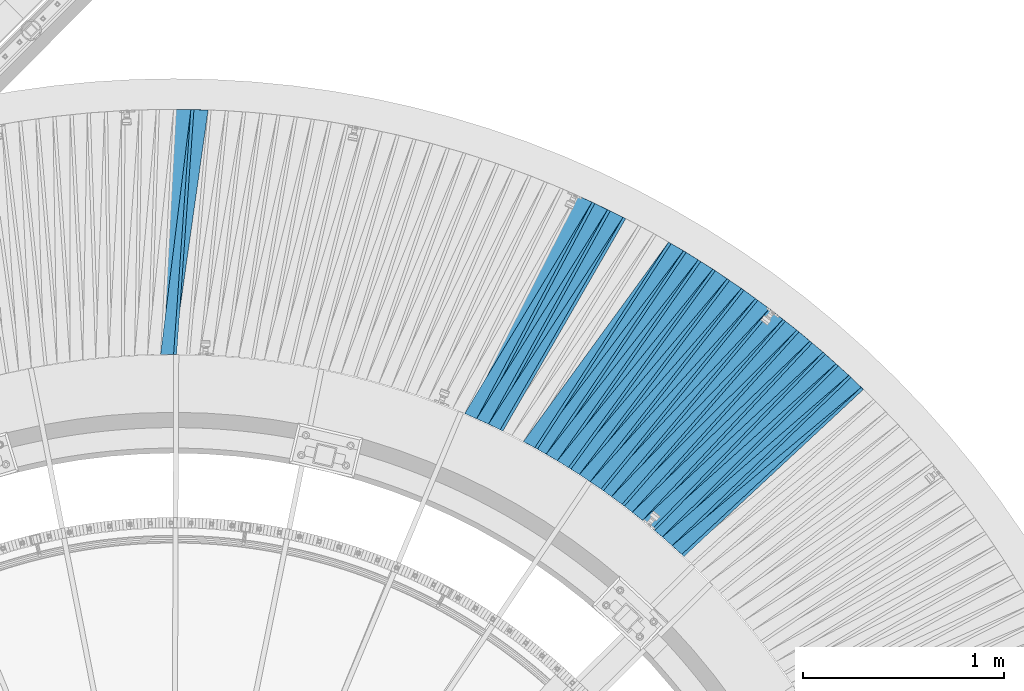
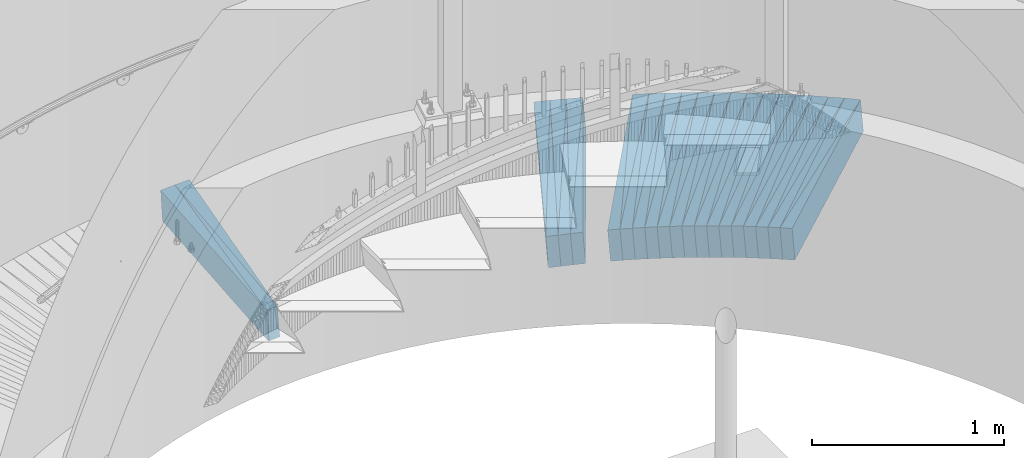
# One storey, part 839 of 975: 38 plates.
"""IFC2X3 building model written with IfcOpenShell, lengths in millimetres."""

from ifc_helpers import new_model, si_unit, frame, origin_with_axes, place, context, subcontext, project, spatial, faceted_brep, material, type_object, element, save


model = new_model("IFC2X3")

# Units and contexts
model_context = context("Model", 3, precision=1e-05, world=origin_with_axes())
body_context = subcontext(model_context, "Body", "Model", "MODEL_VIEW")
ifc_project = project(units=[si_unit("LENGTHUNIT", "METRE", prefix="MILLI"), si_unit("AREAUNIT", "SQUARE_METRE"), si_unit("VOLUMEUNIT", "CUBIC_METRE"), si_unit("MASSUNIT", "GRAM", prefix="KILO"), si_unit("TIMEUNIT", "SECOND"), si_unit("PLANEANGLEUNIT", "RADIAN"), si_unit("SOLIDANGLEUNIT", "STERADIAN"), si_unit("THERMODYNAMICTEMPERATUREUNIT", "DEGREE_CELSIUS"), si_unit("LUMINOUSINTENSITYUNIT", "LUMEN")], contexts=[model_context])

# Site, building, storey
site_placement = place(None, origin_with_axes())
site = spatial("IfcSite", under=ifc_project, at=site_placement, CompositionType="ELEMENT")
building_placement = place(site_placement, origin_with_axes())
building = spatial("IfcBuilding", under=site, at=building_placement, Name="Undefined", CompositionType="ELEMENT")
storey_placement = place(building_placement, origin_with_axes())
storey = spatial("IfcBuildingStorey", under=building, at=storey_placement, Name="Undefined", CompositionType="ELEMENT", Elevation=0.0)

# Plates
ifc_material = material(Name="STEEL/A36")
plate_type_1 = type_object("IfcPlateType", PredefinedType="NOTDEFINED")
plate_1_placement = place(storey_placement, frame((38099.332611681, 7003.60513528373, 227.583742926951), z_axis=(0.692902195275637, -0.718796137720279, 0.0567332370010058), x_axis=(-0.719791776709076, -0.694178449719425, -0.00400975399837932)))
element("IfcPlate", 1, at=plate_1_placement, inside=storey, type_object=plate_type_1, material=ifc_material, Name="SLAB", context=body_context, shape_type="Brep", body=[
    faceted_brep([(-6.82121026329696e-12, -100.000000000011, -1.09139364212751e-10), (-3.06288743015102, -99.9999999999993, 86.152648925814), (-3.062887430111, 99.9999999999941, 86.152648925643), (5.91171556152403e-12, 100.000000000011, 1.09139364212751e-10), (1222.02001953347, -100.000000000119, 4.07453626394272e-10), (1222.02001953351, 99.9999999998747, 2.40106601268053e-10)], [[[0, 1, 2, 3]], [[1, 4, 5, 2]], [[4, 0, 3, 5]], [[5, 3, 2]], [[4, 1, 0]]]),
])
plate_2_placement = place(storey_placement, frame((38035.5068522439, 7061.18243910341, 222.683996557332), z_axis=(0.705269943673761, -0.706662070175819, 0.0567716929925125), x_axis=(-0.707633134888142, -0.706568162888309, -0.00409604699935252)))
element("IfcPlate", 2, at=plate_2_placement, inside=storey, type_object=plate_type_1, material=ifc_material, Name="SLAB", context=body_context, shape_type="Brep", body=[
    faceted_brep([(-6.82121026329696e-12, -100.000000000011, -1.09139364212751e-10), (-4.61015844379654, -99.9999999999782, 85.9779968265284), (-4.61015844324356, 99.9999999999945, 85.9779968260555), (5.91171556152403e-12, 100.000000000011, 1.09139364212751e-10), (1220.6889648426, -99.9999999999197, 1.21508492156863e-09), (1220.68896484315, 100.000000000053, 7.42147676646709e-10)], [[[0, 1, 2, 3]], [[1, 4, 5, 2]], [[4, 0, 3, 5]], [[5, 3, 2]], [[4, 1, 0]]]),
])
plate_3_placement = place(storey_placement, frame((37971.7535841602, 7118.77893265093, 217.690556443741), z_axis=(0.71754201844967, -0.694103313761126, 0.057914087966553), x_axis=(-0.695093831141571, -0.718907382146421, -0.00409167500083336)))
element("IfcPlate", 3, at=plate_3_placement, inside=storey, type_object=plate_type_1, material=ifc_material, Name="SLAB", context=body_context, shape_type="Brep", body=[
    faceted_brep([(-6.82121026329696e-12, -100.000000000011, -1.09139364212751e-10), (-3.02788901347958, -99.9999999999923, 86.120857238926), (-3.02788901320673, 99.9999999999948, 86.1208572386822), (5.91171556152403e-12, 100.000000000011, 1.09139364212751e-10), (1221.99328613304, -100.000000000013, 7.38509697839618e-10), (1221.99328613332, 99.9999999999745, 5.05679054185748e-10)], [[[0, 1, 2, 3]], [[1, 4, 5, 2]], [[4, 0, 3, 5]], [[5, 3, 2]], [[4, 1, 0]]]),
])
plate_4_placement = place(storey_placement, frame((37905.9108681395, 7174.15281361469, 212.690390341702), z_axis=(0.72951557193396, -0.681509850491505, 0.0578908800150302), x_axis=(-0.682479106234621, -0.730894080251266, -0.00401410100137997)))
element("IfcPlate", 4, at=plate_4_placement, inside=storey, type_object=plate_type_1, material=ifc_material, Name="SLAB", context=body_context, shape_type="Brep", body=[
    faceted_brep([(-6.82121026329696e-12, -100.000000000011, -1.09139364212751e-10), (-4.57700109465077, -100.000000000013, 86.0520248411194), (-4.57700109490179, 100.000000000002, 86.0520248413231), (5.91171556152403e-12, 100.000000000011, 1.09139364212751e-10), (1220.69665527125, -99.9999999998367, 4.05634636990726e-09), (1220.696655271, 100.000000000178, 4.2600731831044e-09)], [[[0, 1, 2, 3]], [[1, 4, 5, 2]], [[4, 0, 3, 5]], [[5, 3, 2]], [[4, 1, 0]]]),
])
plate_5_placement = place(storey_placement, frame((37839.9953379372, 7229.61425906099, 207.783905722043), z_axis=(0.74142437056043, -0.668631927303488, 0.0567560439908636), x_axis=(-0.669533099117396, -0.742770953130236, -0.00409150000071739)))
element("IfcPlate", 5, at=plate_5_placement, inside=storey, type_object=plate_type_1, material=ifc_material, Name="SLAB", context=body_context, shape_type="Brep", body=[
    faceted_brep([(-6.82121026329696e-12, -100.000000000011, -1.09139364212751e-10), (-3.06704592683309, -100.000000000017, 86.1133193967107), (-3.06704592694587, 99.9999999999873, 86.1133193967653), (5.91171556152403e-12, 100.000000000011, 1.09139364212751e-10), (1222.04565429959, -100.000000000166, -5.27143129147589e-09), (1222.04565429948, 99.9999999998383, -5.21322363056242e-09)], [[[0, 1, 2, 3]], [[1, 4, 5, 2]], [[4, 0, 3, 5]], [[5, 3, 2]], [[4, 1, 0]]]),
])
plate_6_placement = place(storey_placement, frame((37772.3426986674, 7282.51762294938, 202.790523056195), z_axis=(0.752898197967471, -0.655584444349794, 0.057908029010729), x_axis=(-0.656501707794191, -0.754313416763525, -0.00409596799871593)))
element("IfcPlate", 6, at=plate_6_placement, inside=storey, type_object=plate_type_1, material=ifc_material, Name="SLAB", context=body_context, shape_type="Brep", body=[
    faceted_brep([(-6.82121026329696e-12, -100.000000000011, -1.09139364212751e-10), (-4.62811565390803, -100.000000000002, 86.0164566039566), (-4.62811565436277, 100.000000000029, 86.0164566044659), (5.91171556152403e-12, 100.000000000011, 1.09139364212751e-10), (1220.71276855146, -99.9999999999328, -3.9744918467477e-10), (1220.71276855077, 100.000000000086, -1.79170456249267e-10)], [[[0, 1, 2, 3]], [[1, 4, 5, 2]], [[4, 0, 3, 5]], [[5, 3, 2]], [[4, 1, 0]]]),
])
plate_7_placement = place(storey_placement, frame((37704.7037831676, 7335.48707489499, 197.790972680996), z_axis=(0.764221591446412, -0.642341296560276, 0.0579915330059257), x_axis=(-0.643240646998982, -0.765653572998791, -0.00400951399999368)))
element("IfcPlate", 7, at=plate_7_placement, inside=storey, type_object=plate_type_1, material=ifc_material, Name="SLAB", context=body_context, shape_type="Brep", body=[
    faceted_brep([(-6.82121026329696e-12, -100.000000000011, -1.09139364212751e-10), (-3.06436538692287, -99.9999999999993, 86.0076141357604), (-3.06436538688649, 99.9999999999964, 86.0076141356585), (5.91171556152403e-12, 100.000000000011, 1.09139364212751e-10), (1222.09313964697, -99.9999999999384, 3.65980667993426e-09), (1222.09313964701, 100.000000000057, 3.56158125214279e-09)], [[[0, 1, 2, 3]], [[1, 4, 5, 2]], [[4, 0, 3, 5]], [[5, 3, 2]], [[4, 1, 0]]]),
])
plate_8_placement = place(storey_placement, frame((37635.0716001461, 7386.15374493722, 192.883886656751), z_axis=(0.775289265050165, -0.629051448084569, 0.0567523670051031), x_axis=(-0.629880829859822, -0.77668099182715, -0.00409598699908843)))
element("IfcPlate", 8, at=plate_8_placement, inside=storey, type_object=plate_type_1, material=ifc_material, Name="SLAB", context=body_context, shape_type="Brep", body=[
    faceted_brep([(-6.82121026329696e-12, -100.000000000011, -1.09139364212751e-10), (-4.63738584552993, -99.9999999999759, 86.0053176884103), (-4.63738584523162, 99.9999999999964, 86.0053176879555), (5.91171556152403e-12, 100.000000000011, 1.09139364212751e-10), (1220.70715332002, -100.000000000052, -1.87719706445932e-09), (1220.70715332041, 99.999999999975, -1.38970790430903e-09)], [[[0, 1, 2, 3]], [[1, 4, 5, 2]], [[4, 0, 3, 5]], [[5, 3, 2]], [[4, 1, 0]]]),
])
plate_9_placement = place(storey_placement, frame((37565.6134636427, 7436.75865536407, 187.890456974095), z_axis=(0.786183744220849, -0.615274249093014, 0.0579026659655102), x_axis=(-0.61612014993792, -0.787641975920636, -0.00400981399959597)))
element("IfcPlate", 9, at=plate_9_placement, inside=storey, type_object=plate_type_1, material=ifc_material, Name="SLAB", context=body_context, shape_type="Brep", body=[
    faceted_brep([(-6.82121026329696e-12, -100.000000000011, -1.09139364212751e-10), (-3.04732751804841, -100.000000000028, 86.1407775874468), (-3.04732751853953, 100.000000000002, 86.1407775879306), (5.91171556152403e-12, 100.000000000011, 1.09139364212751e-10), (1222.00195312245, -99.9999999998101, 3.09591996483505e-09), (1222.00195312196, 100.00000000022, 3.57977114617825e-09)], [[[0, 1, 2, 3]], [[1, 4, 5, 2]], [[4, 0, 3, 5]], [[5, 3, 2]], [[4, 1, 0]]]),
])
plate_10_placement = place(storey_placement, frame((37494.2817620801, 7485.01940864123, 182.983828134364), z_axis=(0.796800986630967, -0.601571712148321, 0.0567420729869404), x_axis=(-0.602351630069765, -0.798220356092449, -0.00409595800047439)))
element("IfcPlate", 10, at=plate_10_placement, inside=storey, type_object=plate_type_1, material=ifc_material, Name="SLAB", context=body_context, shape_type="Brep", body=[
    faceted_brep([(-6.82121026329696e-12, -100.000000000011, -1.09139364212751e-10), (-4.5733423231286, -100.000000000017, 86.0255432126178), (-4.57334232348876, 100.000000000016, 86.0255432131344), (5.91171556152403e-12, 100.000000000011, 1.09139364212751e-10), (1220.71557617224, -100.000000000043, -1.96814653463662e-09), (1220.71557617188, 99.9999999999893, -1.45155354402959e-09)], [[[0, 1, 2, 3]], [[1, 4, 5, 2]], [[4, 0, 3, 5]], [[5, 3, 2]], [[4, 1, 0]]]),
])
plate_11_placement = place(storey_placement, frame((37423.2353777171, 7533.13004791603, 177.990965763903), z_axis=(0.807154516305445, -0.587485635011787, 0.0579846140154453), x_axis=(-0.58827867722007, -0.808647919302512, -0.00409152000153062)))
element("IfcPlate", 11, at=plate_11_placement, inside=storey, type_object=plate_type_1, material=ifc_material, Name="SLAB", context=body_context, shape_type="Brep", body=[
    faceted_brep([(-6.82121026329696e-12, -100.000000000011, -1.09139364212751e-10), (-3.00993442539402, -99.9999999999961, 86.0173873902095), (-3.00993442512845, 99.9999999999823, 86.0173873898675), (5.91171556152403e-12, 100.000000000011, 1.09139364212751e-10), (1222.03991699198, -99.9999999999714, -2.47382558882236e-10), (1222.03991699223, 100.000000000007, -5.89352566748857e-10)], [[[0, 1, 2, 3]], [[1, 4, 5, 2]], [[4, 0, 3, 5]], [[5, 3, 2]], [[4, 1, 0]]]),
])
plate_12_placement = place(storey_placement, frame((37350.3783360777, 7578.81353993791, 172.990554416701), z_axis=(0.817242623882158, -0.573375846823387, 0.0579191849888281), x_axis=(-0.574144732315092, -0.818743986449327, -0.00401385200220281)))
element("IfcPlate", 12, at=plate_12_placement, inside=storey, type_object=plate_type_1, material=ifc_material, Name="SLAB", context=body_context, shape_type="Brep", body=[
    faceted_brep([(-6.82121026329696e-12, -100.000000000011, -1.09139364212751e-10), (-4.54049444193879, -100.000000000011, 86.0125198362657), (-4.54049444201883, 100.000000000005, 86.0125198365095), (5.91171556152403e-12, 100.000000000011, 1.09139364212751e-10), (1220.77233886818, -99.9999999999491, -4.98403096571565e-10), (1220.77233886782, 100.00000000001, -1.02227204479277e-09)], [[[0, 1, 2, 3]], [[1, 4, 5, 2]], [[4, 0, 3, 5]], [[5, 3, 2]], [[4, 1, 0]]]),
])
plate_13_placement = place(storey_placement, frame((37277.3359885503, 7624.57484703929, 168.083741629984), z_axis=(0.827285576354071, -0.55891019123171, 0.0567271830240656), x_axis=(-0.559614320961265, -0.828743067942636, -0.0040913459997168)))
element("IfcPlate", 13, at=plate_13_placement, inside=storey, type_object=plate_type_1, material=ifc_material, Name="SLAB", context=body_context, shape_type="Brep", body=[
    faceted_brep([(-6.82121026329696e-12, -100.000000000011, -1.09139364212751e-10), (-3.08120918293571, -99.9999999999829, 86.1561126712004), (-3.08120918281566, 100.00000000001, 86.156112671044), (5.91171556152403e-12, 100.000000000011, 1.09139364212751e-10), (1222.0916748056, -100.000000000054, 2.18278728425503e-10), (1222.09167480573, 99.9999999999382, 5.82076609134674e-11)], [[[0, 1, 2, 3]], [[1, 4, 5, 2]], [[4, 0, 3, 5]], [[5, 3, 2]], [[4, 1, 0]]]),
])
plate_14_placement = place(storey_placement, frame((37202.9824067665, 7667.59761190269, 163.090435109662), z_axis=(0.83679970388577, -0.54443977651877, 0.0578928779806302), x_axis=(-0.545150767679435, -0.838328017507041, -0.00409579799759155)))
element("IfcPlate", 14, at=plate_14_placement, inside=storey, type_object=plate_type_1, material=ifc_material, Name="SLAB", context=body_context, shape_type="Brep", body=[
    faceted_brep([(-6.82121026329696e-12, -100.000000000011, -1.09139364212751e-10), (-4.58610630059775, -99.9999999999809, 86.041954040862), (-4.58610630029943, 99.9999999999955, 86.0419540404437), (5.91171556152403e-12, 100.000000000011, 1.09139364212751e-10), (1220.76318359169, -99.9999999998547, 1.35332811623812e-09), (1220.76318359198, 100.000000000121, 9.31322574615479e-10)], [[[0, 1, 2, 3]], [[1, 4, 5, 2]], [[4, 0, 3, 5]], [[5, 3, 2]], [[4, 1, 0]]]),
])
plate_15_placement = place(storey_placement, frame((36899.5633865199, 7829.35021664011, 143.190487895792), z_axis=(0.872697089004634, -0.484815930613552, 0.0579077219907184), x_axis=(-0.485423400064226, -0.874269988115673, -0.00401379500053107)))
element("IfcPlate", 15, at=plate_15_placement, inside=storey, type_object=plate_type_1, material=ifc_material, Name="SLAB", context=body_context, shape_type="Brep", body=[
    faceted_brep([(-6.82121026329696e-12, -100.000000000011, -1.09139364212751e-10), (-4.58331918730983, -99.9999999999766, 86.0265808109325), (-4.58331918708063, 99.9999999999886, 86.0265808103723), (5.91171556152403e-12, 100.000000000011, 1.09139364212751e-10), (1220.78991699381, -100.00000000014, -1.63709046319127e-10), (1220.78991699404, 99.9999999998251, -7.27595761418343e-10)], [[[0, 1, 2, 3]], [[1, 4, 5, 2]], [[4, 0, 3, 5]], [[5, 3, 2]], [[4, 1, 0]]]),
])
plate_16_placement = place(storey_placement, frame((36822.2056131177, 7867.19571731203, 138.283982035175), z_axis=(0.881130039117038, -0.469453317383957, 0.0567753200149989), x_axis=(-0.470006758754677, -0.882653709539289, -0.00400945899790721)))
element("IfcPlate", 16, at=plate_16_placement, inside=storey, type_object=plate_type_1, material=ifc_material, Name="SLAB", context=body_context, shape_type="Brep", body=[
    faceted_brep([(-6.82121026329696e-12, -100.000000000011, -1.09139364212751e-10), (-3.07512402524662, -100.000000000008, 86.0879440306271), (-3.07512402540669, 100.000000000011, 86.0879440309291), (5.91171556152403e-12, 100.000000000011, 1.09139364212751e-10), (1222.11010742185, -100.000000000017, 1.78988557308912e-09), (1222.11010742169, 100.000000000002, 2.09183781407773e-09)], [[[0, 1, 2, 3]], [[1, 4, 5, 2]], [[4, 0, 3, 5]], [[5, 3, 2]], [[4, 1, 0]]]),
])
plate_17_placement = place(storey_placement, frame((36743.7494105906, 7902.29362699368, 133.384050128795), z_axis=(0.889134527174387, -0.454109783681152, 0.0567811320020773), x_axis=(-0.454632329109627, -0.890669787214767, -0.00409578700098762)))
element("IfcPlate", 17, at=plate_17_placement, inside=storey, type_object=plate_type_1, material=ifc_material, Name="SLAB", context=body_context, shape_type="Brep", body=[
    faceted_brep([(-6.82121026329696e-12, -100.000000000011, -1.09139364212751e-10), (-4.53526449229321, -99.9999999999764, 85.9691314701413), (-4.53526449198762, 99.9999999999966, 85.9691314696429), (5.91171556152403e-12, 100.000000000011, 1.09139364212751e-10), (1220.76672363078, -99.9999999998388, 2.92493496090174e-09), (1220.76672363108, 100.000000000134, 2.42289388552308e-09)], [[[0, 1, 2, 3]], [[1, 4, 5, 2]], [[4, 0, 3, 5]], [[5, 3, 2]], [[4, 1, 0]]]),
])
plate_18_placement = place(storey_placement, frame((34826.3166783219, 8330.40226527761, 19.1908326174983), z_axis=(0.995826887258051, -0.0704882300087428, 0.0579674050150202), x_axis=(-0.0703741460294477, -0.997512607417428, -0.00400969000167793)))
element("IfcPlate", 18, at=plate_18_placement, inside=storey, type_object=plate_type_1, material=ifc_material, Name="SLAB", context=body_context, shape_type="Brep", body=[
    faceted_brep([(-6.82121026329696e-12, -100.000000000011, -1.09139364212751e-10), (-3.0726497173564, -99.9999999999834, 86.0428314211895), (-3.07264971730001, 99.9999999999816, 86.0428314205783), (5.91171556152403e-12, 100.000000000011, 1.09139364212751e-10), (1222.03967285099, -100.000000000101, -1.84081727638841e-09), (1222.03967285105, 99.9999999998638, -2.44472175836563e-09)], [[[0, 1, 2, 3]], [[1, 4, 5, 2]], [[4, 0, 3, 5]], [[5, 3, 2]], [[4, 1, 0]]]),
])
plate_19_placement = place(storey_placement, frame((34740.1945382847, 8330.51849654292, 14.2838561137889), z_axis=(0.99697293194365, -0.0531483873375508, 0.0567469989964257), x_axis=(-0.0530012450046966, -0.998586046088532, -0.00409592300036313)))
element("IfcPlate", 19, at=plate_19_placement, inside=storey, type_object=plate_type_1, material=ifc_material, Name="SLAB", context=body_context, shape_type="Brep", body=[
    faceted_brep([(-6.82121026329696e-12, -100.000000000011, -1.09139364212751e-10), (-4.57817697524297, -100.000000000008, 86.0177307127597), (-4.57817697511928, 99.99999999999, 86.0177307127233), (5.91171556152403e-12, 100.000000000011, 1.09139364212751e-10), (1220.72607422123, -99.9999999999166, 4.15093381889164e-09), (1220.72607422166, 100.000000000095, 4.42742020823061e-09)], [[[0, 1, 2, 3]], [[1, 4, 5, 2]], [[4, 0, 3, 5]], [[5, 3, 2]], [[4, 1, 0]]]),
])
plate_type_2 = type_object("IfcPlateType", PredefinedType="NOTDEFINED")
plate_20_placement = place(storey_placement, frame((38162.4342592262, 6942.3687888943, 232.60700562542), z_axis=(0.639795264899323, -0.764873331319148, 0.0750386970112974), x_axis=(-0.76662606282908, -0.642044237856855, -0.00797975099822089)))
element("IfcPlate", 20, at=plate_20_placement, inside=storey, type_object=plate_type_2, material=ifc_material, Name="SLAB", context=body_context, shape_type="Brep", body=[
    faceted_brep([(-6.82121026329696e-12, -100.000000000011, -1.09139364212751e-10), (1219.05944824473, -100.000000000192, 64.3373413061308), (1219.05944824503, 99.9999999997915, 64.3373413059817), (5.91171556152403e-12, 100.000000000011, 1.09139364212751e-10), (1228.10852051034, -100.000000000189, -7.23957782611251e-10), (1228.10852051064, 99.9999999997942, -8.76752892509103e-10)], [[[0, 1, 2, 3]], [[1, 4, 5, 2]], [[4, 0, 3, 5]], [[5, 3, 2]], [[4, 1, 0]]]),
])
plate_21_placement = place(storey_placement, frame((38100.734738414, 7002.15049205623, 227.719084916616), z_axis=(0.652999154333402, -0.753473092219443, 0.0766185600304), x_axis=(-0.7552641521915, -0.655370963166172, -0.00805984200204361)))
element("IfcPlate", 21, at=plate_21_placement, inside=storey, type_object=plate_type_2, material=ifc_material, Name="SLAB", context=body_context, shape_type="Brep", body=[
    faceted_brep([(-6.82121026329696e-12, -100.000000000011, -1.09139364212751e-10), (1220.32104492109, -99.9999999999386, 64.4177398689353), (1220.32104492095, 100.000000000071, 64.4177398690372), (5.91171556152403e-12, 100.000000000011, 1.09139364212751e-10), (1228.31201171806, -99.9999999999475, 3.51428752765059e-09), (1228.31201171792, 100.000000000062, 3.61615093424916e-09)], [[[0, 1, 2, 3]], [[1, 4, 5, 2]], [[4, 0, 3, 5]], [[5, 3, 2]], [[4, 1, 0]]]),
])
plate_22_placement = place(storey_placement, frame((37973.0086049008, 7117.56482018013, 217.807194284404), z_axis=(0.679010097480502, -0.730282141242371, 0.0750551910395014), x_axis=(-0.731910802901879, -0.681352781908655, -0.00805997399891944)))
element("IfcPlate", 22, at=plate_22_placement, inside=storey, type_object=plate_type_2, material=ifc_material, Name="SLAB", context=body_context, shape_type="Brep", body=[
    faceted_brep([(-6.82121026329696e-12, -100.000000000011, -1.09139364212751e-10), (1220.29370117358, -100.000000000154, 64.4264068586235), (1220.29370117385, 99.9999999998245, 64.426406858358), (5.91171556152403e-12, 100.000000000011, 1.09139364212751e-10), (1228.29174804873, -100.000000000165, -2.15368345379829e-09), (1228.291748049, 99.9999999998138, -2.4156179279089e-09)], [[[0, 1, 2, 3]], [[1, 4, 5, 2]], [[4, 0, 3, 5]], [[5, 3, 2]], [[4, 1, 0]]]),
])
plate_23_placement = place(storey_placement, frame((37841.4959289155, 7228.26088171274, 207.919321932407), z_axis=(0.704057526923797, -0.705995172101074, 0.076640823011771), x_axis=(-0.707612312955058, -0.706553988955124, -0.00814096099948294)))
element("IfcPlate", 23, at=plate_23_placement, inside=storey, type_object=plate_type_2, material=ifc_material, Name="SLAB", context=body_context, shape_type="Brep", body=[
    faceted_brep([(-6.82121026329696e-12, -100.000000000011, -1.09139364212751e-10), (1220.34814452882, -99.9999999997715, 64.3887481718812), (1220.34814452895, 100.000000000221, 64.3887481717647), (5.91171556152403e-12, 100.000000000011, 1.09139364212751e-10), (1228.35620116926, -99.9999999997576, 2.27737473323941e-09), (1228.35620116939, 100.000000000235, 2.16459739021957e-09)], [[[0, 1, 2, 3]], [[1, 4, 5, 2]], [[4, 0, 3, 5]], [[5, 3, 2]], [[4, 1, 0]]]),
])
plate_24_placement = place(storey_placement, frame((37706.1477668558, 7334.27328817624, 197.918453277608), z_axis=(0.728189994313762, -0.681088480812943, 0.0765363540106269), x_axis=(-0.682617987210978, -0.730730954225846, -0.00805953300249095)))
element("IfcPlate", 24, at=plate_24_placement, inside=storey, type_object=plate_type_2, material=ifc_material, Name="SLAB", context=body_context, shape_type="Brep", body=[
    faceted_brep([(-6.82121026329696e-12, -100.000000000011, -1.09139364212751e-10), (1220.39050292674, -99.9999999997515, 64.4893112211394), (1220.39050292719, 100.000000000209, 64.4893112206337), (5.91171556152403e-12, 100.000000000011, 1.09139364212751e-10), (1228.35913085633, -99.9999999997422, 6.584741640836e-10), (1228.35913085678, 100.000000000217, 1.56433088704944e-10)], [[[0, 1, 2, 3]], [[1, 4, 5, 2]], [[4, 0, 3, 5]], [[5, 3, 2]], [[4, 1, 0]]]),
])
plate_25_placement = place(storey_placement, frame((37567.1083376304, 7435.5886616408, 188.018688343724), z_axis=(0.751533852557012, -0.65523612021516, 0.076566932981542), x_axis=(-0.656677272175076, -0.75412863520106, -0.00805988700214888)))
element("IfcPlate", 25, at=plate_25_placement, inside=storey, type_object=plate_type_2, material=ifc_material, Name="SLAB", context=body_context, shape_type="Brep", body=[
    faceted_brep([(-6.82121026329696e-12, -100.000000000011, -1.09139364212751e-10), (1220.30065918156, -100.000000000219, 64.4597473115791), (1220.30065918199, 99.9999999997399, 64.4597473111062), (5.91171556152403e-12, 100.000000000011, 1.09139364212751e-10), (1228.30505371279, -100.000000000214, -2.9831426218152e-10), (1228.30505371321, 99.9999999997447, -7.74889485910535e-10)], [[[0, 1, 2, 3]], [[1, 4, 5, 2]], [[4, 0, 3, 5]], [[5, 3, 2]], [[4, 1, 0]]]),
])
plate_26_placement = place(storey_placement, frame((37424.6415965817, 7532.10645759857, 178.107207761939), z_axis=(0.77403745178172, -0.628675169657322, 0.0750570069720265), x_axis=(-0.629962032769016, -0.776584108715256, -0.00805973699704479)))
element("IfcPlate", 26, at=plate_26_placement, inside=storey, type_object=plate_type_2, material=ifc_material, Name="SLAB", context=body_context, shape_type="Brep", body=[
    faceted_brep([(-6.82121026329696e-12, -100.000000000011, -1.09139364212751e-10), (1220.340454102, -100.000000000121, 64.4259948715735), (1220.34045410174, 99.9999999999147, 64.4259948719955), (5.91171556152403e-12, 100.000000000011, 1.09139364212751e-10), (1228.32800293014, -100.000000000121, -4.00905264541507e-09), (1228.32800292988, 99.9999999999152, -3.58340912498534e-09)], [[[0, 1, 2, 3]], [[1, 4, 5, 2]], [[4, 0, 3, 5]], [[5, 3, 2]], [[4, 1, 0]]]),
])
plate_27_placement = place(storey_placement, frame((37279.0036300738, 7623.44809576633, 168.21847182041), z_axis=(0.795443310310692, -0.601176409086161, 0.0765301590239834), x_axis=(-0.602426087257993, -0.798133156341804, -0.00814089300348636)))
element("IfcPlate", 27, at=plate_27_placement, inside=storey, type_object=plate_type_2, material=ifc_material, Name="SLAB", context=body_context, shape_type="Brep", body=[
    faceted_brep([(-6.82121026329696e-12, -100.000000000011, -1.09139364212751e-10), (1220.3891601561, -100.00000000004, 64.4851379389438), (1220.38916015629, 99.9999999999466, 64.485137938751), (5.91171556152403e-12, 100.000000000011, 1.09139364212751e-10), (1228.36645507786, -100.000000000028, -1.0077201295644e-09), (1228.36645507804, 99.9999999999584, -1.19325704872608e-09)], [[[0, 1, 2, 3]], [[1, 4, 5, 2]], [[4, 0, 3, 5]], [[5, 3, 2]], [[4, 1, 0]]]),
])
plate_28_placement = place(storey_placement, frame((36978.3333346927, 7790.69268792783, 148.306981554145), z_axis=(0.835505625462958, -0.544335650389073, 0.0750269920445708), x_axis=(-0.545348303176916, -0.838170791271907, -0.00805933500261448)))
element("IfcPlate", 28, at=plate_28_placement, inside=storey, type_object=plate_type_2, material=ifc_material, Name="SLAB", context=body_context, shape_type="Brep", body=[
    faceted_brep([(-6.82121026329696e-12, -100.000000000011, -1.09139364212751e-10), (1220.41455077975, -99.9999999997501, 64.4531936674939), (1220.41455077963, 100.000000000272, 64.4531936677849), (5.91171556152403e-12, 100.000000000011, 1.09139364212751e-10), (1228.38928222515, -99.9999999997615, 4.62750904262066e-09), (1228.38928222502, 100.00000000026, 4.92218532599509e-09)], [[[0, 1, 2, 3]], [[1, 4, 5, 2]], [[4, 0, 3, 5]], [[5, 3, 2]], [[4, 1, 0]]]),
])
plate_29_placement = place(storey_placement, frame((36823.9837630238, 7866.24825203144, 138.418980448294), z_axis=(0.853894414196939, -0.514777630228961, 0.0766049660212749), x_axis=(-0.515747556080664, -0.856702689133992, -0.00805982800126059)))
element("IfcPlate", 29, at=plate_29_placement, inside=storey, type_object=plate_type_2, material=ifc_material, Name="SLAB", context=body_context, shape_type="Brep", body=[
    faceted_brep([(-6.82121026329696e-12, -100.000000000011, -1.09139364212751e-10), (1220.41003417776, -99.999999999714, 64.4383163488892), (1220.41003417766, 100.000000000297, 64.4383163490384), (5.91171556152403e-12, 100.000000000011, 1.09139364212751e-10), (1228.31408691215, -99.9999999997185, 1.61890056915581e-09), (1228.31408691205, 100.000000000293, 1.76441972143948e-09)], [[[0, 1, 2, 3]], [[1, 4, 5, 2]], [[4, 0, 3, 5]], [[5, 3, 2]], [[4, 1, 0]]]),
])
plate_30_placement = place(storey_placement, frame((34828.2110869355, 8330.26809923597, 19.3192538044665), z_axis=(0.98944983763133, -0.12294407852481, 0.0766405399708287), x_axis=(-0.122687920061808, -0.992412572499965, -0.00805979000406042)))
element("IfcPlate", 30, at=plate_30_placement, inside=storey, type_object=plate_type_2, material=ifc_material, Name="SLAB", context=body_context, shape_type="Brep", body=[
    faceted_brep([(-6.82121026329696e-12, -100.000000000011, -1.09139364212751e-10), (1220.3415527335, -100.000000000009, 64.4006042478213), (1220.34155273357, 99.9999999999359, 64.4006042471156), (5.91171556152403e-12, 100.000000000011, 1.09139364212751e-10), (1228.31982421788, -100.000000000006, 6.11180439591408e-10), (1228.31982421794, 99.9999999999391, -9.45874489843845e-11)], [[[0, 1, 2, 3]], [[1, 4, 5, 2]], [[4, 0, 3, 5]], [[5, 3, 2]], [[4, 1, 0]]]),
])
plate_type_3 = type_object("IfcPlateType", PredefinedType="NOTDEFINED")
plate_31_placement = place(storey_placement, frame((38036.9381969843, 7059.74814927482, 222.819874607754), z_axis=(0.666048612275654, -0.741953127450122, 0.0767124680391561), x_axis=(-0.743702591488105, -0.668461028438722, -0.00814302600534439)))
element("IfcPlate", 31, at=plate_31_placement, inside=storey, type_object=plate_type_3, material=ifc_material, Name="SLAB", context=body_context, shape_type="Brep", body=[
    faceted_brep([(-6.82121026329696e-12, -100.000000000011, -1.09139364212751e-10), (1218.99865722904, -100.000000000251, 64.2182159394142), (1218.9986572292, 99.999999999741, 64.2182159393269), (5.91171556152403e-12, 100.000000000011, 1.09139364212751e-10), (1228.044677737, -100.000000000262, -2.63753463514149e-09), (1228.04467773716, 99.9999999997297, -2.7212081477046e-09)], [[[0, 1, 2, 3]], [[1, 4, 5, 2]], [[4, 0, 3, 5]], [[5, 3, 2]], [[4, 1, 0]]]),
])
plate_32_placement = place(storey_placement, frame((37907.3076715062, 7172.84782580711, 212.81962245188), z_axis=(0.691593654973987, -0.718204088406802, 0.0766883550187109), x_axis=(-0.719871761939827, -0.694060275941982, -0.00806099999932615)))
element("IfcPlate", 32, at=plate_32_placement, inside=storey, type_object=plate_type_3, material=ifc_material, Name="SLAB", context=body_context, shape_type="Brep", body=[
    faceted_brep([(-6.82121026329696e-12, -100.000000000011, -1.09139364212751e-10), (1219.00524902344, -99.9999999999698, 64.2392425542857), (1219.00524902301, 100.000000000072, 64.2392425547514), (5.91171556152403e-12, 100.000000000011, 1.09139364212751e-10), (1228.13537597672, -99.9999999999841, -3.34694050252438e-10), (1228.13537597628, 100.000000000058, 1.34605215862393e-10)], [[[0, 1, 2, 3]], [[1, 4, 5, 2]], [[4, 0, 3, 5]], [[5, 3, 2]], [[4, 1, 0]]]),
])
plate_33_placement = place(storey_placement, frame((37773.6632763132, 7281.36764909791, 202.907522511745), z_axis=(0.716363903412981, -0.69367351325357, 0.0750987010364803), x_axis=(-0.695179081014871, -0.718791395015374, -0.0080607550001724)))
element("IfcPlate", 33, at=plate_33_placement, inside=storey, type_object=plate_type_3, material=ifc_material, Name="SLAB", context=body_context, shape_type="Brep", body=[
    faceted_brep([(-6.82121026329696e-12, -100.000000000011, -1.09139364212751e-10), (1219.01989745943, -99.9999999998331, 64.2650451680383), (1219.0198974592, 100.000000000183, 64.2650451682421), (5.91171556152403e-12, 100.000000000011, 1.09139364212751e-10), (1228.17272949059, -99.9999999998286, 1.69893610291183e-09), (1228.17272949035, 100.000000000187, 1.90993887372315e-09)], [[[0, 1, 2, 3]], [[1, 4, 5, 2]], [[4, 0, 3, 5]], [[5, 3, 2]], [[4, 1, 0]]]),
])
plate_34_placement = place(storey_placement, frame((37636.525279126, 7384.97417107004, 193.007929606425), z_axis=(0.740063054068443, -0.668325334659648, 0.0751526649890565), x_axis=(-0.669747887049754, -0.742544801055163, -0.00806140300059888)))
element("IfcPlate", 34, at=plate_34_placement, inside=storey, type_object=plate_type_3, material=ifc_material, Name="SLAB", context=body_context, shape_type="Brep", body=[
    faceted_brep([(-6.82121026329696e-12, -100.000000000011, -1.09139364212751e-10), (1219.01623535049, -99.9999999998768, 64.2290039078143), (1219.01623535094, 100.000000000089, 64.2290039073887), (5.91171556152403e-12, 100.000000000011, 1.09139364212751e-10), (1228.07409667845, -99.9999999998645, 2.91765900328755e-09), (1228.0740966789, 100.000000000101, 2.49201548285782e-09)], [[[0, 1, 2, 3]], [[1, 4, 5, 2]], [[4, 0, 3, 5]], [[5, 3, 2]], [[4, 1, 0]]]),
])
plate_35_placement = place(storey_placement, frame((37495.902174896, 7483.79591703105, 183.119964439864), z_axis=(0.762879346099428, -0.641972356783808, 0.0767241579970219), x_axis=(-0.643369347254879, -0.765512623303271, -0.00814288500322593)))
element("IfcPlate", 35, at=plate_35_placement, inside=storey, type_object=plate_type_3, material=ifc_material, Name="SLAB", context=body_context, shape_type="Brep", body=[
    faceted_brep([(-6.82121026329696e-12, -100.000000000011, -1.09139364212751e-10), (1219.02563476752, -100.000000000219, 64.2090606663405), (1219.02563476724, 99.999999999802, 64.2090606665952), (5.91171556152403e-12, 100.000000000011, 1.09139364212751e-10), (1228.06591797055, -100.000000000212, -7.23957782611251e-10), (1228.06591797026, 99.999999999809, -4.69299266114831e-10)], [[[0, 1, 2, 3]], [[1, 4, 5, 2]], [[4, 0, 3, 5]], [[5, 3, 2]], [[4, 1, 0]]]),
])
plate_36_placement = place(storey_placement, frame((37351.9451185068, 7577.71419803657, 173.120029008899), z_axis=(0.784816713519425, -0.614958135754512, 0.0767412369583942), x_axis=(-0.616268481073015, -0.787494880093299, -0.00806058700095497)))
element("IfcPlate", 36, at=plate_36_placement, inside=storey, type_object=plate_type_3, material=ifc_material, Name="SLAB", context=body_context, shape_type="Brep", body=[
    faceted_brep([(-6.82121026329696e-12, -100.000000000011, -1.09139364212751e-10), (1219.08325195093, -99.9999999997142, 64.196586612361), (1219.08325195126, 100.00000000025, 64.1965866119244), (5.91171556152403e-12, 100.000000000011, 1.09139364212751e-10), (1228.19848632576, -99.9999999997003, 4.83487383462489e-09), (1228.1984863261, 100.000000000264, 4.39831637777388e-09)], [[[0, 1, 2, 3]], [[1, 4, 5, 2]], [[4, 0, 3, 5]], [[5, 3, 2]], [[4, 1, 0]]]),
])
plate_37_placement = place(storey_placement, frame((37204.4550430113, 7666.63940739903, 163.207848806034), z_axis=(0.805931550262473, -0.587220588007852, 0.0751419810175354), x_axis=(-0.588375272928616, -0.8085478079019, -0.00806105099902198)))
element("IfcPlate", 37, at=plate_37_placement, inside=storey, type_object=plate_type_3, material=ifc_material, Name="SLAB", context=body_context, shape_type="Brep", body=[
    faceted_brep([(-6.82121026329696e-12, -100.000000000011, -1.09139364212751e-10), (1219.07189941345, -99.9999999999111, 64.2383956918784), (1219.0718994137, 100.00000000006, 64.238395691511), (5.91171556152403e-12, 100.000000000011, 1.09139364212751e-10), (1228.12780761653, -99.9999999999054, -1.52067514136434e-09), (1228.12780761678, 100.000000000065, -1.89174897968769e-09)], [[[0, 1, 2, 3]], [[1, 4, 5, 2]], [[4, 0, 3, 5]], [[5, 3, 2]], [[4, 1, 0]]]),
])
plate_38_placement = place(storey_placement, frame((36901.09877367, 7828.49718028808, 143.307890612149), z_axis=(0.844889089069742, -0.52963568780804, 0.0751562729983717), x_axis=(-0.530611323011368, -0.847577700018155, -0.00797911800017091)))
element("IfcPlate", 38, at=plate_38_placement, inside=storey, type_object=plate_type_3, material=ifc_material, Name="SLAB", context=body_context, shape_type="Brep", body=[
    faceted_brep([(-6.82121026329696e-12, -100.000000000011, -1.09139364212751e-10), (1219.09899902333, -99.9999999999181, 64.230628968231), (1219.09899902341, 100.000000000076, 64.2306289682019), (5.91171556152403e-12, 100.000000000011, 1.09139364212751e-10), (1228.20593261718, -99.9999999999277, 2.77577782981098e-09), (1228.20593261725, 100.000000000067, 2.74667399935424e-09)], [[[0, 1, 2, 3]], [[1, 4, 5, 2]], [[4, 0, 3, 5]], [[5, 3, 2]], [[4, 1, 0]]]),
])

save(model, "model.ifc")
